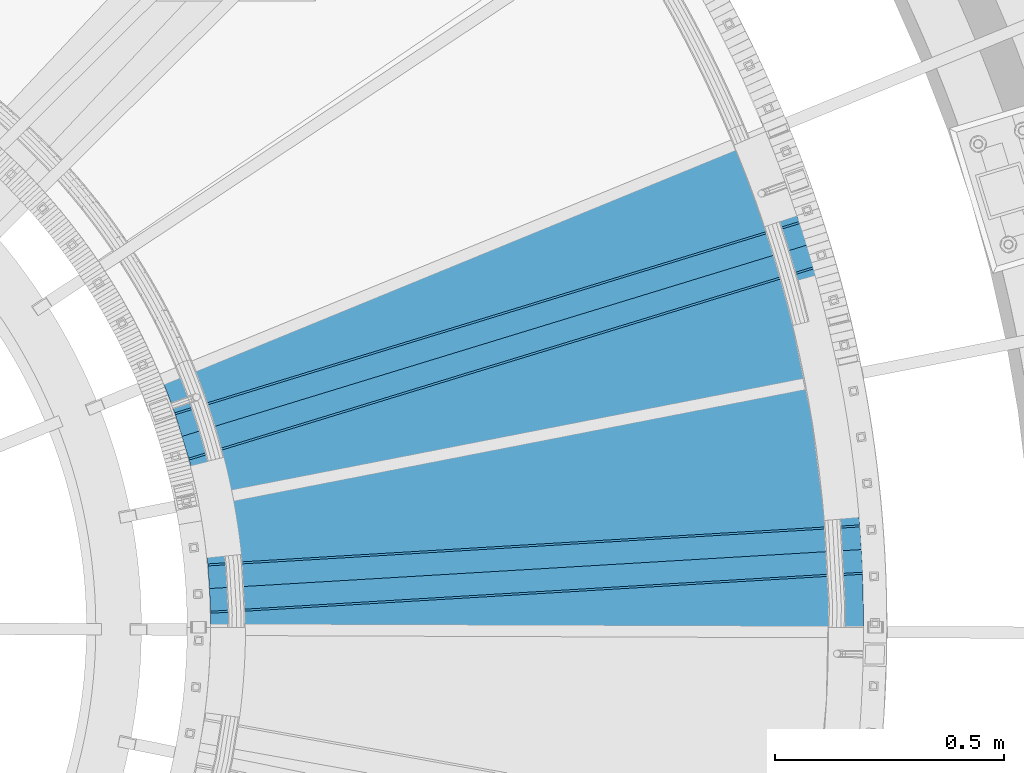
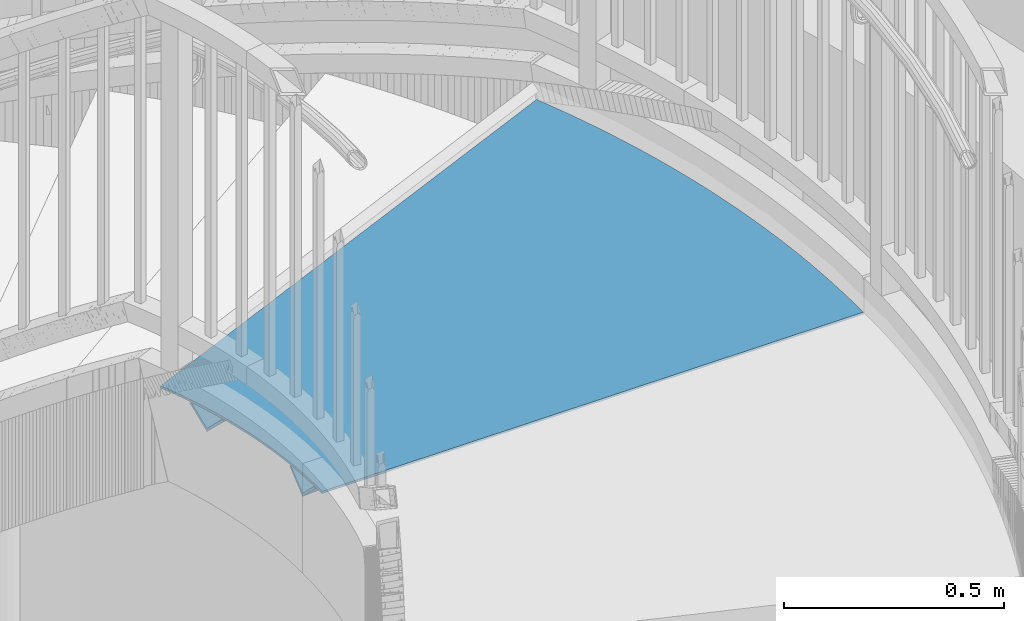
# One storey, part 361 of 975: 3 beams.
"""IFC2X3 building model written with IfcOpenShell, lengths in millimetres."""

from ifc_helpers import new_model, si_unit, frame, origin_with_axes, place, context, subcontext, project, spatial, faceted_brep, material, type_object, element, save


model = new_model("IFC2X3")

# Units and contexts
model_context = context("Model", 3, precision=1e-05, world=origin_with_axes())
body_context = subcontext(model_context, "Body", "Model", "MODEL_VIEW")
ifc_project = project(units=[si_unit("LENGTHUNIT", "METRE", prefix="MILLI"), si_unit("AREAUNIT", "SQUARE_METRE"), si_unit("VOLUMEUNIT", "CUBIC_METRE"), si_unit("MASSUNIT", "GRAM", prefix="KILO"), si_unit("TIMEUNIT", "SECOND"), si_unit("PLANEANGLEUNIT", "RADIAN"), si_unit("SOLIDANGLEUNIT", "STERADIAN"), si_unit("THERMODYNAMICTEMPERATUREUNIT", "DEGREE_CELSIUS"), si_unit("LUMINOUSINTENSITYUNIT", "LUMEN")], contexts=[model_context])

# Site, building, storey
site_placement = place(None, origin_with_axes())
site = spatial("IfcSite", under=ifc_project, at=site_placement, CompositionType="ELEMENT")
building_placement = place(site_placement, origin_with_axes())
building = spatial("IfcBuilding", under=site, at=building_placement, Name="Undefined", CompositionType="ELEMENT")
storey_placement = place(building_placement, origin_with_axes())
storey = spatial("IfcBuildingStorey", under=building, at=storey_placement, Name="Undefined", CompositionType="ELEMENT", Elevation=0.0)

# Beams
ifc_material = material(Name="STEEL/A36")
beam_type_1 = type_object("IfcBeamType", Name="L3X3X1/4", PredefinedType="NOTDEFINED")
for number, where, z_axis, x_axis, name in (
    (1, (36154.2749606036, 3488.20195832578, 2078.30987194315), (-0.0422115680446368, 0.705845722213214, 0.707106781155802), (0.998216593253556, 0.0596961720151634, 0.0), "ANGLE"),
    (2, (36094.5724080513, 3819.67868843171, 2078.30987194315), (-0.207002052433767, 0.676128797241737, 0.707106781065385), (0.95619051480643, 0.292745109940737, 0.0), "ANGLE"),
):
    element("IfcBeam", number, at=place(storey_placement, frame(where, z_axis=z_axis, x_axis=x_axis)), inside=storey, type_object=beam_type_1, material=ifc_material, Name=name, ObjectType="L3X3X1/4", context=body_context, shape_type="Brep", body=[
        faceted_brep([(-6.18456397205591e-11, 38.0999999999876, -38.1000000000258), (1.45519152283669e-10, 38.1000000000295, 38.1000000000386), (1423.28392836863, 38.0999999996639, 38.0999999996748), (1423.28392836842, 38.0999999996202, -38.1000000003896), (1.41881173476577e-10, 31.7500000000291, 38.1000000000404), (1423.28392836862, 31.7499999996635, 38.0999999996766), (-5.45696821063757e-11, 31.7499999999909, -31.75000000002), (1423.28392836843, 31.7499999996235, -31.7500000003856), (-1.23691279441118e-10, -38.100000000024, -31.7500000000309), (1423.28392836836, -38.1000000003878, -31.7500000003965), (-1.41881173476577e-10, -38.1000000000258, -38.1000000000386), (1423.28392836833, -38.1000000003933, -38.100000000406)], [[[0, 1, 2, 3]], [[1, 4, 5, 2]], [[4, 6, 7, 5]], [[6, 8, 9, 7]], [[8, 10, 11, 9]], [[10, 0, 3, 11]], [[5, 7, 9, 11, 3, 2]], [[10, 8, 6, 4, 1, 0]]]),
    ])
beam_type_2 = type_object("IfcBeamType", PredefinedType="NOTDEFINED")
beam_placement = place(storey_placement, frame((36699.3915501, 4235.8612108004, 2085.975), z_axis=(-0.979944348149513, -0.199271359030408, 0.0), x_axis=(0.199271359030408, -0.979944348149513, 0.0)))
element("IfcBeam", 3, at=beam_placement, inside=storey, type_object=beam_type_2, material=ifc_material, Name="TREAD", context=body_context, shape_type="Brep", body=[
    faceted_brep([(693.055984751516, 3.17500000000018, 694.515555696322), (693.055984751516, -3.17500000000018, 694.515555696322), (702.390515653582, -3.17500000000018, 696.415490012805), (702.390515653582, 3.17500000000018, 696.415490012805), (683.708522602119, 3.17500000000018, 692.680298511586), (683.708522602119, -3.17500000000018, 692.680298511586), (674.348577334947, 3.17500000000018, 690.90980644324), (674.348577334947, -3.17500000000018, 690.90980644324), (664.976597678019, 3.17500000000018, 689.204164370967), (664.976597678019, -3.17500000000018, 689.204164370967), (655.593032936298, 3.17500000000018, 687.563454065501), (655.593032936298, -3.17500000000018, 687.563454065501), (646.198332970151, 3.17500000000018, 685.987754184614), (646.198332970151, -3.17500000000018, 685.987754184614), (636.792948173777, 3.17500000000018, 684.477140269439), (636.792948173777, -3.17500000000018, 684.477140269439), (627.377329453629, 3.17500000000018, 683.031684740781), (627.377329453629, -3.17500000000018, 683.031684740781), (617.95192820678, 3.17500000000018, 681.651456895663), (617.95192820678, -3.17500000000018, 681.651456895663), (608.517196299293, 3.17500000000018, 680.336522904014), (608.517196299293, -3.17500000000018, 680.336522904014), (599.073586044556, 3.17500000000018, 679.086945805488), (599.073586044556, -3.17500000000018, 679.086945805488), (589.621550181593, 3.17500000000018, 677.902785506449), (589.621550181593, -3.17500000000018, 677.902785506449), (580.161541853367, 3.17500000000018, 676.784098777091), (580.161541853367, -3.17500000000018, 676.784098777091), (570.69401458505, 3.17500000000018, 675.730939248715), (570.69401458505, -3.17500000000018, 675.730939248715), (561.219422262281, 3.17500000000018, 674.743357411164), (561.219422262281, -3.17500000000018, 674.743357411164), (551.738219109406, 3.17500000000018, 673.82140061041), (551.738219109406, -3.17500000000018, 673.82140061041), (542.250859667704, 3.17500000000018, 672.965113046273), (542.250859667704, -3.17500000000018, 672.965113046273), (532.757798773597, 3.17500000000018, 672.174535770282), (532.757798773597, -3.17500000000018, 672.174535770282), (523.259491536839, 3.17500000000018, 671.449706683758), (523.259491536839, -3.17500000000018, 671.449706683758), (513.756393318701, 3.17500000000018, 670.790660535946), (513.756393318701, -3.17500000000018, 670.790660535946), (504.248959710138, 3.17500000000018, 670.197428922387), (504.248959710138, -3.17500000000018, 670.197428922387), (494.737646509955, 3.17500000000018, 669.670040283374), (494.737646509955, -3.17500000000018, 669.670040283374), (485.222909702945, 3.17500000000018, 669.208519902626), (485.222909702945, -3.17500000000018, 669.208519902626), (475.705205438032, 3.17500000000018, 668.812889906018), (475.705205438032, -3.17500000000018, 668.812889906018), (466.184990006411, 3.17500000000018, 668.483169260566), (466.184990006411, -3.17500000000018, 668.483169260566), (456.662719819657, 3.17500000000018, 668.219373773514), (456.662719819657, -3.17500000000018, 668.219373773514), (447.138851387859, 3.17500000000018, 668.021516091561), (447.138851387859, -3.17500000000018, 668.021516091561), (437.613841297722, 3.17500000000018, 667.889605700278), (437.613841297722, -3.17500000000018, 667.889605700278), (428.08814619069, 3.17500000000018, 667.823648923601), (428.08814619069, -3.17500000000018, 667.823648923601), (418.562222741044, 3.17500000000018, 667.823648923593), (418.562222741044, -3.17500000000018, 667.823648923593), (409.036527634012, 3.17500000000018, 667.889605700264), (409.036527634012, -3.17500000000018, 667.889605700264), (399.511517543875, 3.17500000000018, 668.02151609154), (399.511517543875, -3.17500000000018, 668.02151609154), (389.987649112079, 3.17500000000018, 668.219373773471), (389.987649112079, -3.17500000000018, 668.219373773471), (380.465378925324, 3.17500000000018, 668.483169260508), (380.465378925324, -3.17500000000018, 668.483169260508), (370.945163493703, 3.17500000000018, 668.812889905945), (370.945163493703, -3.17500000000018, 668.812889905945), (361.427459228793, 3.17500000000018, 669.208519902546), (361.427459228793, -3.17500000000018, 669.208519902546), (351.912722421784, 3.17500000000018, 669.670040283294), (351.912722421784, -3.17500000000018, 669.670040283294), (342.401409221601, 3.17500000000018, 670.197428922285), (342.401409221601, -3.17500000000018, 670.197428922285), (332.893975613041, 3.17500000000018, 670.790660535829), (332.893975613041, -3.17500000000018, 670.790660535829), (323.390877394902, 3.17500000000018, 671.449706683634), (323.390877394902, -3.17500000000018, 671.449706683634), (313.892570158146, 3.17500000000018, 672.174535770151), (313.892570158146, -3.17500000000018, 672.174535770151), (304.39950926404, 3.17500000000018, 672.965113046128), (304.39950926404, -3.17500000000018, 672.965113046128), (294.912149822341, 3.17500000000018, 673.821400610257), (294.912149822341, -3.17500000000018, 673.821400610257), (285.430946669468, 3.17500000000018, 674.743357410996), (285.430946669468, -3.17500000000018, 674.743357410996), (275.9563543467, 3.17500000000018, 675.730939248526), (275.9563543467, -3.17500000000018, 675.730939248526), (266.488827078384, 3.17500000000018, 676.784098776901), (266.488827078384, -3.17500000000018, 676.784098776901), (257.028818750161, 3.17500000000018, 677.902785506245), (257.028818750161, -3.17500000000018, 677.902785506245), (247.576782887202, 3.17500000000018, 679.086945805262), (247.576782887202, -3.17500000000018, 679.086945805262), (238.133172632465, 3.17500000000018, 680.336522903781), (238.133172632465, -3.17500000000018, 680.336522903781), (228.698440724982, 3.17500000000018, 681.651456895415), (228.698440724982, -3.17500000000018, 681.651456895415), (219.273039478134, 3.17500000000018, 683.031684740527), (219.273039478134, -3.17500000000018, 683.031684740527), (209.85742075799, 3.17500000000018, 684.477140269169), (209.85742075799, -3.17500000000018, 684.477140269169), (200.45203596162, 3.17500000000018, 685.987754184331), (200.45203596162, -3.17500000000018, 685.987754184331), (191.057335995475, 3.17500000000018, 687.563454065203), (191.057335995475, -3.17500000000018, 687.563454065203), (181.673771253757, 3.17500000000018, 689.204164370662), (181.673771253757, -3.17500000000018, 689.204164370662), (172.301791596833, 3.17500000000018, 690.90980644292), (172.301791596833, -3.17500000000018, 690.90980644292), (162.941846329666, 3.17500000000018, 692.680298511259), (162.941846329666, -3.17500000000018, 692.680298511259), (153.59438418027, 3.17500000000018, 694.515555695987), (153.59438418027, -3.17500000000018, 694.515555695987), (150.107968470244, 3.17500000000018, 695.22517473506), (150.107968470244, -3.17500000000018, 695.22517473506), (-134.003958479626, 3.17500000000018, -698.502957146949), (-134.003958479626, -3.17500000000018, -698.502957146949), (-125.274549543746, 3.17500000000018, -700.279725982327), (-125.274549543746, -3.17500000000018, -700.279725982327), (-106.262945220544, 3.17500000000018, -704.012416510472), (-106.262945220544, -3.17500000000018, -704.012416510472), (-87.2259517497841, 3.17500000000018, -707.613382646814), (-87.2259517497841, -3.17500000000018, -707.613382646814), (-68.1644817898286, 3.17500000000018, -711.082451756316), (-68.1644817898286, -3.17500000000018, -711.082451756316), (-49.0794491724764, 3.17500000000018, -714.419457527285), (-49.0794491724764, -3.17500000000018, -714.419457527285), (-29.9717688591527, 3.17500000000018, -717.624239979297), (-29.9717688591527, -3.17500000000018, -717.624239979297), (-10.842356897042, 3.17500000000018, -720.696645470875), (-10.842356897042, -3.17500000000018, -720.696645470875), (8.30786962482944, 3.17500000000018, -723.636526706898), (8.30786962482944, -3.17500000000018, -723.636526706898), (27.4779926195552, 3.17500000000018, -726.443742745614), (27.4779926195552, -3.17500000000018, -726.443742745614), (46.667093046367, 3.17500000000018, -729.118159005411), (46.667093046367, -3.17500000000018, -729.118159005411), (65.8742509546937, 3.17500000000018, -731.65964727127), (65.8742509546937, -3.17500000000018, -731.65964727127), (85.098545528268, 3.17500000000018, -734.068085700921), (85.098545528268, -3.17500000000018, -734.068085700921), (104.339055129262, 3.17500000000018, -736.34335883068), (104.339055129262, -3.17500000000018, -736.34335883068), (123.594857342483, 3.17500000000018, -738.485357580976), (123.594857342483, -3.17500000000018, -738.485357580976), (142.865029019588, 3.17500000000018, -740.493979261591), (142.865029019588, -3.17500000000018, -740.493979261591), (162.148646323347, 3.17500000000018, -742.369127576567), (162.148646323347, -3.17500000000018, -742.369127576567), (181.444784771927, 3.17500000000018, -744.110712628855), (181.444784771927, -3.17500000000018, -744.110712628855), (200.752519283208, 3.17500000000018, -745.718650924573), (200.752519283208, -3.17500000000018, -745.718650924573), (220.070924219151, 3.17500000000018, -747.192865377066), (220.070924219151, -3.17500000000018, -747.192865377066), (239.399073430157, 3.17500000000018, -748.533285310565), (239.399073430157, -3.17500000000018, -748.533285310565), (258.736040299475, 3.17500000000018, -749.739846463577), (258.736040299475, -3.17500000000018, -749.739846463577), (278.080897787622, 3.17500000000018, -750.812490992001), (278.080897787622, -3.17500000000018, -750.812490992001), (297.43271847683, 3.17500000000018, -751.751167471826), (297.43271847683, -3.17500000000018, -751.751167471826), (316.790574615507, 3.17500000000018, -752.555830901707), (316.790574615507, -3.17500000000018, -752.555830901707), (336.153538162711, 3.17500000000018, -753.226442704996), (336.153538162711, -3.17500000000018, -753.226442704996), (355.520680832648, 3.17500000000018, -753.762970731717), (355.520680832648, -3.17500000000018, -753.762970731717), (374.891074139165, 3.17500000000018, -754.165389259986), (374.891074139165, -3.17500000000018, -754.165389259986), (394.263789440278, 3.17500000000018, -754.433678997353), (394.263789440278, -3.17500000000018, -754.433678997353), (413.637897982674, 3.17500000000018, -754.567827081642), (413.637897982674, -3.17500000000018, -754.567827081642), (433.012470946256, 3.17500000000018, -754.567827081628), (433.012470946256, -3.17500000000018, -754.567827081628), (452.386579488654, 3.17500000000018, -754.433678997317), (452.386579488654, -3.17500000000018, -754.433678997317), (471.759294789766, 3.17500000000018, -754.165389259928), (471.759294789766, -3.17500000000018, -754.165389259928), (491.129688096285, 3.17500000000018, -753.76297073163), (491.129688096285, -3.17500000000018, -753.76297073163), (510.496830766223, 3.17500000000018, -753.226442704894), (510.496830766223, -3.17500000000018, -753.226442704894), (529.859794313429, 3.17500000000018, -752.555830901576), (529.859794313429, -3.17500000000018, -752.555830901576), (549.217650452107, 3.17500000000018, -751.751167471673), (549.217650452107, -3.17500000000018, -751.751167471673), (568.569471141318, 3.17500000000018, -750.812490991812), (568.569471141318, -3.17500000000018, -750.812490991812), (587.914328629466, 3.17500000000018, -749.739846463366), (587.914328629466, -3.17500000000018, -749.739846463366), (607.251295498785, 3.17500000000018, -748.533285310332), (607.251295498785, -3.17500000000018, -748.533285310332), (626.579444709794, 3.17500000000018, -747.192865376812), (626.579444709794, -3.17500000000018, -747.192865376812), (645.897849645741, 3.17500000000018, -745.718650924289), (645.897849645741, -3.17500000000018, -745.718650924289), (665.205584157026, 3.17500000000018, -744.110712628542), (665.205584157026, -3.17500000000018, -744.110712628542), (684.501722605608, 3.17500000000018, -742.369127576247), (684.501722605608, -3.17500000000018, -742.369127576247), (703.785339909369, 3.17500000000018, -740.493979261235), (703.785339909369, -3.17500000000018, -740.493979261235), (723.055511586479, 3.17500000000018, -738.485357580597), (723.055511586479, -3.17500000000018, -738.485357580597), (742.311313799706, 3.17500000000018, -736.34335883028), (742.311313799706, -3.17500000000018, -736.34335883028), (761.551823400703, 3.17500000000018, -734.068085700492), (761.551823400703, -3.17500000000018, -734.068085700492), (780.776117974282, 3.17500000000018, -731.659647270819), (780.776117974282, -3.17500000000018, -731.659647270819), (799.983275882615, 3.17500000000018, -729.118159004931), (799.983275882615, -3.17500000000018, -729.118159004931), (819.172376309431, 3.17500000000018, -726.443742745119), (819.172376309431, -3.17500000000018, -726.443742745119), (838.342499304163, 3.17500000000018, -723.636526706381), (838.342499304163, -3.17500000000018, -723.636526706381), (857.49272582604, 3.17500000000018, -720.696645470336), (857.49272582604, -3.17500000000018, -720.696645470336), (876.622137788157, 3.17500000000018, -717.624239978722), (876.622137788157, -3.17500000000018, -717.624239978722), (895.729818101486, 3.17500000000018, -714.419457526688), (895.729818101486, -3.17500000000018, -714.419457526688), (914.814850718845, 3.17500000000018, -711.082451755698), (914.814850718845, -3.17500000000018, -711.082451755698), (933.876320678808, 3.17500000000018, -707.613382646166), (933.876320678808, -3.17500000000018, -707.613382646166), (952.913314149575, 3.17500000000018, -704.012416509802), (952.913314149575, -3.17500000000018, -704.012416509802), (971.924918472783, 3.17500000000018, -700.279725981643), (971.924918472783, -3.17500000000018, -700.279725981643), (990.910222207256, -3.17500000000018, -696.415490011743), (707.46118532723, -3.17500000000018, 697.48418127247), (707.46118532723, 3.17500000000018, 697.48418127247), (990.910222207256, 3.17500000000018, -696.415490011743)], [[[0, 1, 2, 3]], [[4, 5, 1, 0]], [[6, 7, 5, 4]], [[8, 9, 7, 6]], [[10, 11, 9, 8]], [[12, 13, 11, 10]], [[14, 15, 13, 12]], [[16, 17, 15, 14]], [[18, 19, 17, 16]], [[20, 21, 19, 18]], [[22, 23, 21, 20]], [[24, 25, 23, 22]], [[26, 27, 25, 24]], [[28, 29, 27, 26]], [[30, 31, 29, 28]], [[32, 33, 31, 30]], [[34, 35, 33, 32]], [[36, 37, 35, 34]], [[38, 39, 37, 36]], [[40, 41, 39, 38]], [[42, 43, 41, 40]], [[44, 45, 43, 42]], [[46, 47, 45, 44]], [[48, 49, 47, 46]], [[50, 51, 49, 48]], [[52, 53, 51, 50]], [[54, 55, 53, 52]], [[56, 57, 55, 54]], [[58, 59, 57, 56]], [[60, 61, 59, 58]], [[62, 63, 61, 60]], [[64, 65, 63, 62]], [[66, 67, 65, 64]], [[68, 69, 67, 66]], [[70, 71, 69, 68]], [[72, 73, 71, 70]], [[74, 75, 73, 72]], [[76, 77, 75, 74]], [[78, 79, 77, 76]], [[80, 81, 79, 78]], [[82, 83, 81, 80]], [[84, 85, 83, 82]], [[86, 87, 85, 84]], [[88, 89, 87, 86]], [[90, 91, 89, 88]], [[92, 93, 91, 90]], [[94, 95, 93, 92]], [[96, 97, 95, 94]], [[98, 99, 97, 96]], [[100, 101, 99, 98]], [[102, 103, 101, 100]], [[104, 105, 103, 102]], [[106, 107, 105, 104]], [[108, 109, 107, 106]], [[110, 111, 109, 108]], [[112, 113, 111, 110]], [[114, 115, 113, 112]], [[116, 117, 115, 114]], [[117, 116, 118, 119]], [[120, 121, 119, 118]], [[122, 123, 121, 120]], [[123, 122, 124, 125]], [[125, 124, 126, 127]], [[127, 126, 128, 129]], [[129, 128, 130, 131]], [[131, 130, 132, 133]], [[133, 132, 134, 135]], [[135, 134, 136, 137]], [[137, 136, 138, 139]], [[139, 138, 140, 141]], [[141, 140, 142, 143]], [[143, 142, 144, 145]], [[145, 144, 146, 147]], [[147, 146, 148, 149]], [[149, 148, 150, 151]], [[151, 150, 152, 153]], [[153, 152, 154, 155]], [[155, 154, 156, 157]], [[157, 156, 158, 159]], [[159, 158, 160, 161]], [[161, 160, 162, 163]], [[163, 162, 164, 165]], [[165, 164, 166, 167]], [[167, 166, 168, 169]], [[169, 168, 170, 171]], [[171, 170, 172, 173]], [[173, 172, 174, 175]], [[175, 174, 176, 177]], [[177, 176, 178, 179]], [[179, 178, 180, 181]], [[181, 180, 182, 183]], [[183, 182, 184, 185]], [[185, 184, 186, 187]], [[187, 186, 188, 189]], [[189, 188, 190, 191]], [[191, 190, 192, 193]], [[193, 192, 194, 195]], [[195, 194, 196, 197]], [[197, 196, 198, 199]], [[199, 198, 200, 201]], [[201, 200, 202, 203]], [[203, 202, 204, 205]], [[205, 204, 206, 207]], [[207, 206, 208, 209]], [[209, 208, 210, 211]], [[211, 210, 212, 213]], [[213, 212, 214, 215]], [[215, 214, 216, 217]], [[217, 216, 218, 219]], [[219, 218, 220, 221]], [[221, 220, 222, 223]], [[223, 222, 224, 225]], [[225, 224, 226, 227]], [[227, 226, 228, 229]], [[229, 228, 230, 231]], [[231, 230, 232, 233]], [[233, 232, 234, 235]], [[235, 234, 236, 237]], [[2, 1, 5, 7, 9, 11, 13, 15, 17, 19, 21, 23, 25, 27, 29, 31, 33, 35, 37, 39, 41, 43, 45, 47, 49, 51, 53, 55, 57, 59, 61, 63, 65, 67, 69, 71, 73, 75, 77, 79, 81, 83, 85, 87, 89, 91, 93, 95, 97, 99, 101, 103, 105, 107, 109, 111, 113, 115, 117, 119, 121, 123, 125, 127, 129, 131, 133, 135, 137, 139, 141, 143, 145, 147, 149, 151, 153, 155, 157, 159, 161, 163, 165, 167, 169, 171, 173, 175, 177, 179, 181, 183, 185, 187, 189, 191, 193, 195, 197, 199, 201, 203, 205, 207, 209, 211, 213, 215, 217, 219, 221, 223, 225, 227, 229, 231, 233, 235, 237, 238, 239]], [[3, 2, 239, 240]], [[236, 234, 232, 230, 228, 226, 224, 222, 220, 218, 216, 214, 212, 210, 208, 206, 204, 202, 200, 198, 196, 194, 192, 190, 188, 186, 184, 182, 180, 178, 176, 174, 172, 170, 168, 166, 164, 162, 160, 158, 156, 154, 152, 150, 148, 146, 144, 142, 140, 138, 136, 134, 132, 130, 128, 126, 124, 122, 120, 118, 116, 114, 112, 110, 108, 106, 104, 102, 100, 98, 96, 94, 92, 90, 88, 86, 84, 82, 80, 78, 76, 74, 72, 70, 68, 66, 64, 62, 60, 58, 56, 54, 52, 50, 48, 46, 44, 42, 40, 38, 36, 34, 32, 30, 28, 26, 24, 22, 20, 18, 16, 14, 12, 10, 8, 6, 4, 0, 3, 240, 241]], [[237, 236, 241, 238]], [[240, 239, 238, 241]]]),
])

save(model, "model.ifc")
